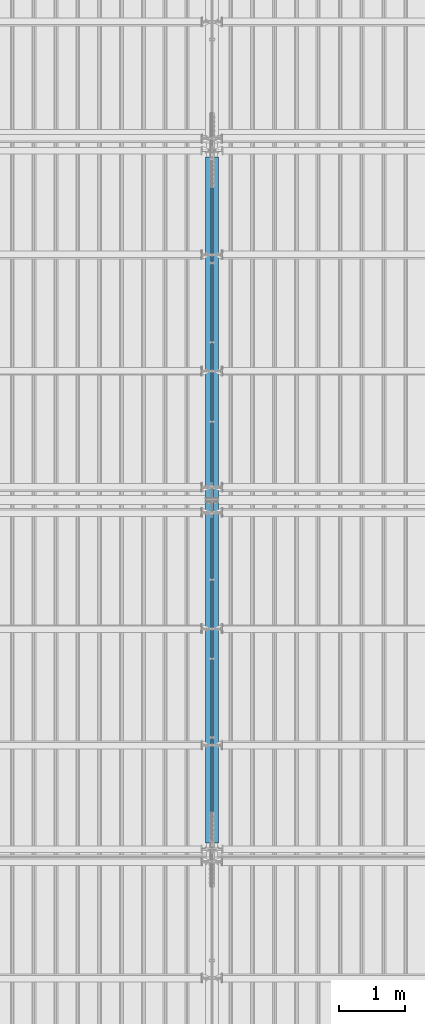
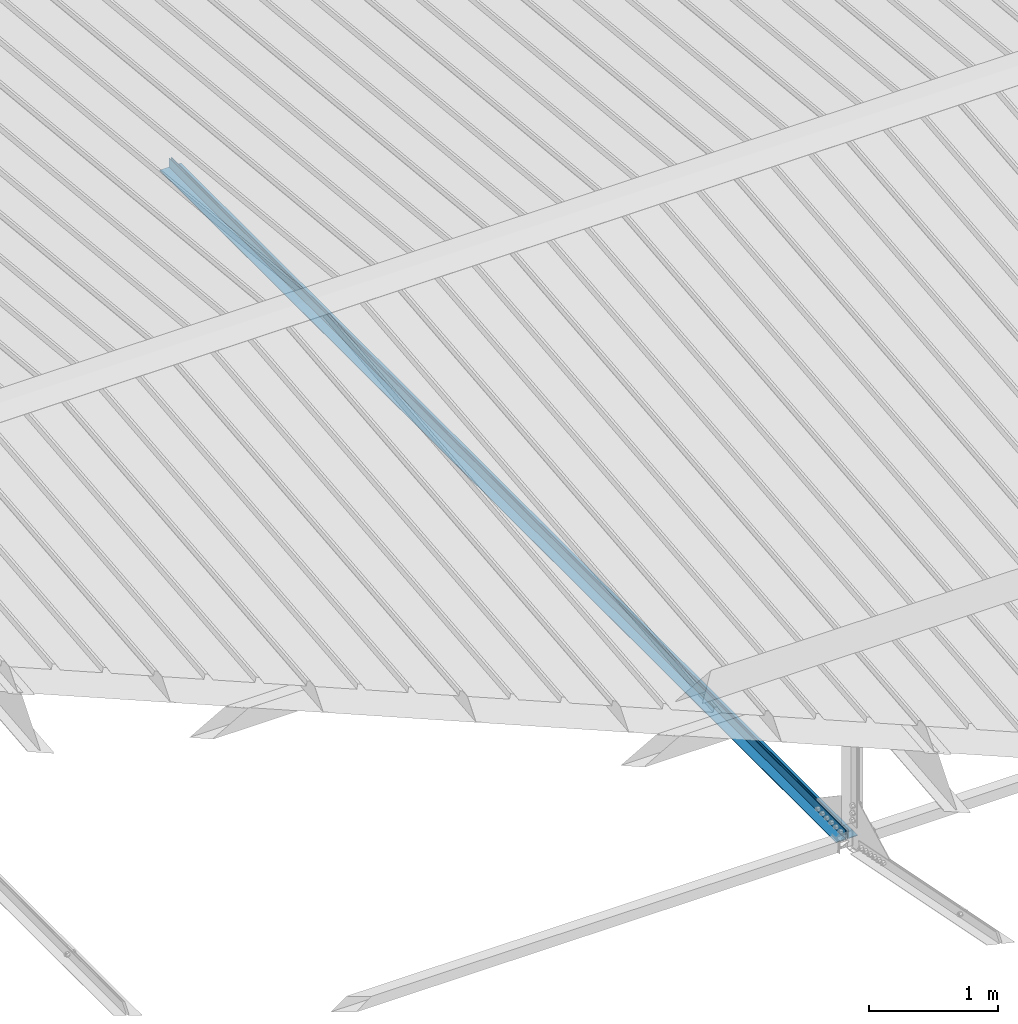
# One storey, part 258 of 709: 2 beams, 2 elements without a shape of their own.
"""IFC4 building model written with IfcOpenShell, lengths in millimetres."""

import ifcopenshell
import ifcopenshell.guid

model = None  # the IFC model being written
_history = None  # IfcOwnerHistory: only IFC2X3 demands one
_inside = {}  # id of a spatial element -> (the spatial element, [elements in it])
_under = {}  # id of a project, library or spatial element -> (it, [spatial elements below it])
_declared = {}  # id of a project -> (the project, [libraries it declares])
_typed = {}  # id of a type object -> (the type object, [elements of that type])
_made_of = {}  # id of a material, layer set ... -> (it, [elements and type objects made of it])


def new_model(schema):
    """Start an empty IFC model of exactly this schema.

    Asked for "IFC4X3", IfcOpenShell would pick the latest addendum, in which some entities
    have other attributes; the version numbers below select the first issue.
    IFC2X3 requires an IfcOwnerHistory on every rooted entity: one is made here for all.
    """
    global model, _history
    if schema == "IFC4X3":
        model = ifcopenshell.file(schema_version=(4, 3, 0, 0))
    else:
        model = ifcopenshell.file(schema=schema)
    _inside.clear()
    _under.clear()
    _declared.clear()
    _typed.clear()
    _made_of.clear()
    _history = None
    if model.schema == "IFC2X3":
        org = make("IfcOrganization", Name="unknown")
        user = make(
            "IfcPersonAndOrganization",
            ThePerson=make("IfcPerson", FamilyName="unknown"),
            TheOrganization=org,
        )
        app = make(
            "IfcApplication",
            ApplicationDeveloper=org,
            Version="unknown",
            ApplicationFullName="unknown",
            ApplicationIdentifier="unknown",
        )
        _history = make(
            "IfcOwnerHistory",
            OwningUser=user,
            OwningApplication=app,
            ChangeAction="ADDED",
            CreationDate=0,
        )
    return model


def make(cls, **values):
    """One entity of the class cls with the attributes given. An attribute that is None is left unset."""
    return model.create_entity(
        cls, **{name: value for name, value in values.items() if value is not None}
    )


def rooted(cls, **values):
    """An entity with a GlobalId (a new one), such as an element, a storey or a relation."""
    return make(cls, GlobalId=ifcopenshell.guid.new(), OwnerHistory=_history, **values)


def si_unit(unit_type, name, prefix=None):
    """IfcSIUnit, for example si_unit("LENGTHUNIT", "METRE", prefix="MILLI")."""
    return make("IfcSIUnit", UnitType=unit_type, Prefix=prefix, Name=name)


def assignment(units):
    """IfcUnitAssignment: the units of a project."""
    return None if units is None else make("IfcUnitAssignment", Units=units)


def point(xyz):
    """IfcCartesianPoint."""
    return None if xyz is None else make("IfcCartesianPoint", Coordinates=xyz)


def direction(xyz):
    """IfcDirection."""
    return None if xyz is None else make("IfcDirection", DirectionRatios=xyz)


def frame(location, z_axis=None, x_axis=None):
    """IfcAxis2Placement3D, a coordinate frame: its origin and axes. An axis left out is left unset."""
    return make(
        "IfcAxis2Placement3D",
        Location=point(location),
        Axis=direction(z_axis),
        RefDirection=direction(x_axis),
    )


def origin_with_axes():
    """The frame at (0, 0, 0) with the z axis (0, 0, 1) and the x axis (1, 0, 0) written out."""
    return frame((0.0, 0.0, 0.0), z_axis=(0.0, 0.0, 1.0), x_axis=(1.0, 0.0, 0.0))


def place(relative_to, where):
    """IfcLocalPlacement: puts the frame where relative to a parent placement (None: the world)."""
    return make(
        "IfcLocalPlacement", PlacementRelTo=relative_to, RelativePlacement=where
    )


def context(
    kind, dimensions, precision=None, world=None, true_north=None, identifier=None
):
    """IfcGeometricRepresentationContext, for example the 3D "Model" context."""
    return make(
        "IfcGeometricRepresentationContext",
        ContextIdentifier=identifier,
        ContextType=kind,
        CoordinateSpaceDimension=dimensions,
        Precision=precision,
        WorldCoordinateSystem=world,
        TrueNorth=true_north,
    )


def subcontext(parent, identifier, kind, view, scale=None):
    """IfcGeometricRepresentationSubContext, for example "Body" below "Model"."""
    return make(
        "IfcGeometricRepresentationSubContext",
        ContextIdentifier=identifier,
        ContextType=kind,
        ParentContext=parent,
        TargetScale=scale,
        TargetView=view,
    )


def project(units=None, contexts=None):
    """IfcProject with its units and contexts."""
    return rooted(
        "IfcProject",
        Name="project",
        RepresentationContexts=contexts,
        UnitsInContext=assignment(units),
    )


def spatial(cls, under=None, at=None, **own):
    """A site, building, storey or space (cls), placed at a placement, below another one or the project."""
    s = rooted(cls, ObjectPlacement=at, **own)
    if under is not None:
        _under.setdefault(under.id(), (under, []))[1].append(s)
    return s


def point_list(points):
    """IfcCartesianPointList2D or 3D."""
    cls = (
        "IfcCartesianPointList2D" if len(points[0]) == 2 else "IfcCartesianPointList3D"
    )
    return make(cls, CoordList=points)


def polygons(points, faces, closed=None, point_numbers=None):
    """IfcPolygonalFaceSet: a face is its outer loop, then its inner loops; points numbered from 1."""
    made = []
    for loops in faces:
        if len(loops) == 1:
            made.append(make("IfcIndexedPolygonalFace", CoordIndex=loops[0]))
        else:
            made.append(
                make(
                    "IfcIndexedPolygonalFaceWithVoids",
                    CoordIndex=loops[0],
                    InnerCoordIndices=loops[1:],
                )
            )
    return make(
        "IfcPolygonalFaceSet",
        Coordinates=point_list(points),
        Closed=closed,
        Faces=made,
        PnIndex=point_numbers,
    )


def shape(context_of_items, identifier, shape_type, items):
    """IfcShapeRepresentation: the items that make up one representation, for example the "Body"."""
    return make(
        "IfcShapeRepresentation",
        ContextOfItems=context_of_items,
        RepresentationIdentifier=identifier,
        RepresentationType=shape_type,
        Items=items,
    )


def material(Name=None, Category=None):
    """IfcMaterial."""
    return make("IfcMaterial", Name=Name, Category=Category)


def made_of(thing, what):
    """Note that an element or type object is made of a material, layer set ...; save() writes the relation."""
    if what is not None:
        _made_of.setdefault(what.id(), (what, []))[1].append(thing)
    return thing


def element(
    cls,
    number,
    at=None,
    inside=None,
    cuts=None,
    type_object=None,
    material=None,
    context=None,
    identifier="Body",
    shape_type=None,
    held_by="IfcProductDefinitionShape",
    body=None,
    shapes=None,
    **own,
):
    """One element of the class cls, such as IfcWall. Its Tag is "e" and its number.

    at: its placement. inside: the storey or other place that contains it. cuts: it is an
    opening in that element (IfcRelVoidsElement). A single representation is given by context,
    identifier, shape_type and body (its items); several are given by shapes. held_by: the class
    of the entity that holds the representations. save() writes the other relations.
    """
    e = rooted(cls, Tag="e%d" % number, ObjectPlacement=at, **own)
    if body is not None:
        shapes = [shape(context, identifier, shape_type, body)]
    if shapes is not None:
        e.Representation = make(held_by, Representations=shapes)
    if inside is not None:
        _inside.setdefault(inside.id(), (inside, []))[1].append(e)
    if cuts is not None:
        rooted(
            "IfcRelVoidsElement", RelatingBuildingElement=cuts, RelatedOpeningElement=e
        )
    if type_object is not None:
        _typed.setdefault(type_object.id(), (type_object, []))[1].append(e)
    return made_of(e, material)


def aggregate(whole, parts):
    """IfcRelAggregates: a whole, such as a stair, and the parts it consists of."""
    return rooted("IfcRelAggregates", RelatingObject=whole, RelatedObjects=parts)


def save(model, path):
    """Write the relations noted so far, then the file.

    IfcRelAggregates (storeys below a building ...), IfcRelContainedInSpatialStructure (elements
    in a storey), IfcRelDefinesByType, IfcRelAssociatesMaterial and IfcRelDeclares: one each for
    every whole, place, type object, material and project.
    """
    for whole, parts in _under.values():
        aggregate(whole, parts)
    for where, things in _inside.values():
        rooted(
            "IfcRelContainedInSpatialStructure",
            RelatedElements=things,
            RelatingStructure=where,
        )
    for kind, things in _typed.values():
        rooted("IfcRelDefinesByType", RelatedObjects=things, RelatingType=kind)
    for what, things in _made_of.values():
        rooted("IfcRelAssociatesMaterial", RelatedObjects=things, RelatingMaterial=what)
    for by, libraries in _declared.values():
        rooted("IfcRelDeclares", RelatingContext=by, RelatedDefinitions=libraries)
    model.write(path)


model = new_model("IFC4")

# Units and contexts
model_context = context("Model", 3, precision=0.2, world=origin_with_axes(), true_north=direction((0.0, 1.0)))
body_context = subcontext(model_context, "Body", "Model", "MODEL_VIEW")
ifc_project = project(units=[si_unit("LENGTHUNIT", "METRE", prefix="MILLI"), si_unit("AREAUNIT", "SQUARE_METRE"), si_unit("VOLUMEUNIT", "CUBIC_METRE"), si_unit("MASSUNIT", "GRAM", prefix="KILO"), si_unit("TIMEUNIT", "SECOND"), si_unit("PLANEANGLEUNIT", "RADIAN"), si_unit("SOLIDANGLEUNIT", "STERADIAN"), si_unit("THERMODYNAMICTEMPERATUREUNIT", "DEGREE_CELSIUS"), si_unit("LUMINOUSINTENSITYUNIT", "LUMEN")], contexts=[model_context])

# Site, building, storey
site_placement = place(None, origin_with_axes())
site = spatial("IfcSite", under=ifc_project, at=site_placement, CompositionType="ELEMENT")
building_placement = place(site_placement, origin_with_axes())
building = spatial("IfcBuilding", under=site, at=building_placement, Name="Undefined", CompositionType="ELEMENT")
storey_placement = place(building_placement, origin_with_axes())
storey = spatial("IfcBuildingStorey", under=building, at=storey_placement, Name="Undefined", CompositionType="ELEMENT", Elevation=0.0)

# Assembly, beam
assembly_1_placement = place(storey_placement, frame((21949.0, 5673.0, 6045.00002), z_axis=(0.0, 0.0, 1.0), x_axis=(0.0, 1.0, 0.0)))
assembly_1 = element("IfcElementAssembly", 1, at=assembly_1_placement, inside=storey)
ifc_material = material(Name="C345-5", Category="STEEL")
beam_1_placement = place(assembly_1_placement, origin_with_axes())
beam_1 = element("IfcBeam", 2, at=beam_1_placement, material=ifc_material, ObjectType="433", context=body_context, shape_type="Tessellation", body=[
    polygons([(100.0, -45.0, -45.0), (100.0, 45.0, -45.0), (10554.0, 45.0, -45.0), (10554.0, -45.0, -45.0), (100.0, 45.0, -39.0), (10554.0, 45.0, -39.0), (100.0, -39.0, -39.0), (10554.0, -39.0, -39.0), (100.0, -39.0, 45.0), (10554.0, -39.0, 45.0), (100.0, -45.0, 45.0), (10554.0, -45.0, 45.0)], [[[1, 2, 3, 4]], [[2, 5, 6, 3]], [[5, 7, 8, 6]], [[7, 9, 10, 8]], [[9, 11, 12, 10]], [[11, 1, 4, 12]], [[6, 8, 10, 12, 4, 3]], [[11, 9, 7, 5, 2, 1]]], closed=True),
])
aggregate(assembly_1, [beam_1])

assembly_2_placement = place(storey_placement, frame((22051.0, 16327.0, 6045.00002), z_axis=(0.0, 0.0, 1.0), x_axis=(0.0, -1.0, 0.0)))
assembly_2 = element("IfcElementAssembly", 3, at=assembly_2_placement, inside=storey)
beam_2_placement = place(assembly_2_placement, origin_with_axes())
beam_2 = element("IfcBeam", 4, at=beam_2_placement, material=ifc_material, ObjectType="434", context=body_context, shape_type="Tessellation", body=[
    polygons([(100.0, -45.0, -45.0), (100.0, 45.0, -45.0), (10554.0, 45.0, -45.0), (10554.0, -45.0, -45.0), (100.0, 45.0, -39.0), (10554.0, 45.0, -39.0), (100.0, -39.0, -39.0), (10554.0, -39.0, -39.0), (100.0, -39.0, 45.0), (10554.0, -39.0, 45.0), (100.0, -45.0, 45.0), (10554.0, -45.0, 45.0)], [[[1, 2, 3, 4]], [[2, 5, 6, 3]], [[5, 7, 8, 6]], [[7, 9, 10, 8]], [[9, 11, 12, 10]], [[11, 1, 4, 12]], [[6, 8, 10, 12, 4, 3]], [[11, 9, 7, 5, 2, 1]]], closed=True),
])
aggregate(assembly_2, [beam_2])

save(model, "model.ifc")
